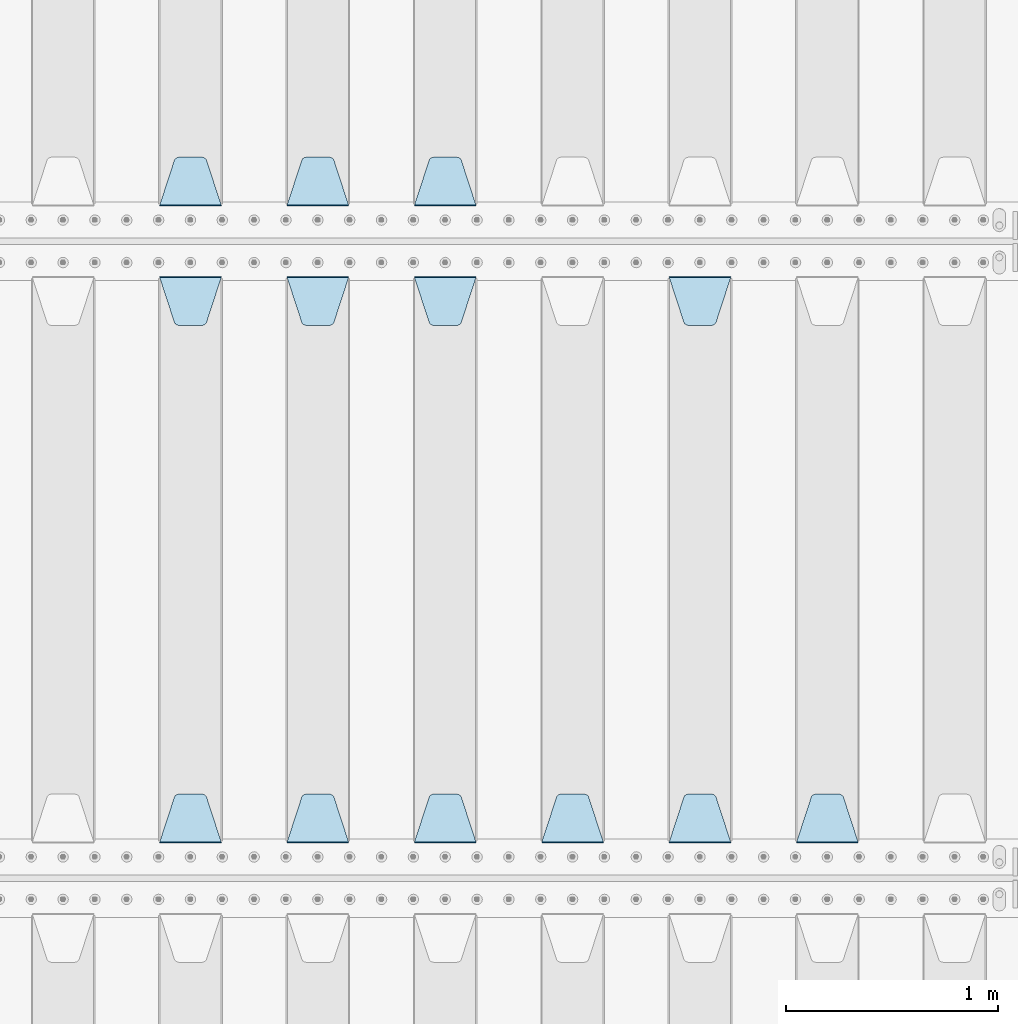
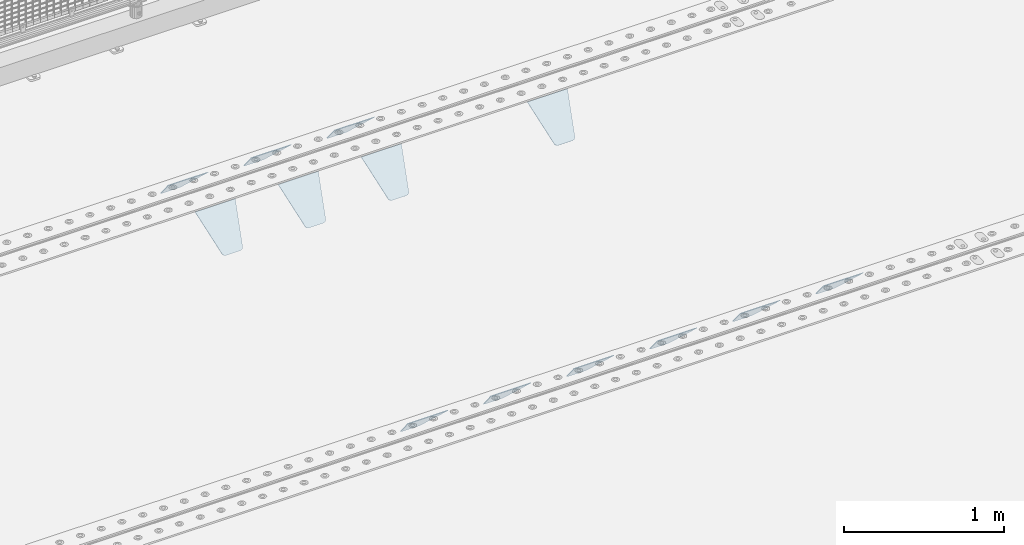
# One storey, part 219 of 270: 13 plates.
"""IFC2X3 building model written with IfcOpenShell, lengths in millimetres."""

from ifc_helpers import new_model, si_unit, frame, origin_with_axes, place, context, subcontext, project, spatial, faceted_brep, material, type_object, element, save


model = new_model("IFC2X3")

# Units and contexts
model_context = context("Model", 3, precision=1e-05, world=origin_with_axes())
body_context = subcontext(model_context, "Body", "Model", "MODEL_VIEW")
ifc_project = project(units=[si_unit("LENGTHUNIT", "METRE", prefix="MILLI"), si_unit("AREAUNIT", "SQUARE_METRE"), si_unit("VOLUMEUNIT", "CUBIC_METRE"), si_unit("MASSUNIT", "GRAM", prefix="KILO"), si_unit("TIMEUNIT", "SECOND"), si_unit("PLANEANGLEUNIT", "RADIAN"), si_unit("SOLIDANGLEUNIT", "STERADIAN"), si_unit("THERMODYNAMICTEMPERATUREUNIT", "DEGREE_CELSIUS"), si_unit("LUMINOUSINTENSITYUNIT", "LUMEN")], contexts=[model_context])

# Site, building, storey
site_placement = place(None, origin_with_axes())
site = spatial("IfcSite", under=ifc_project, at=site_placement, CompositionType="ELEMENT")
building_placement = place(site_placement, origin_with_axes())
building = spatial("IfcBuilding", under=site, at=building_placement, Name="Standard", CompositionType="ELEMENT")
storey_placement = place(building_placement, origin_with_axes())
storey = spatial("IfcBuildingStorey", under=building, at=storey_placement, Name="Undefined", CompositionType="ELEMENT", Elevation=0.0)

# Plates
ifc_material = material(Name="STEEL/S355N")
plate_type = type_object("IfcPlateType", PredefinedType="NOTDEFINED")
plate_1_placement = place(storey_placement, frame((4745.0, -17831.767766953, -1.76776695296758), z_axis=(0.0, 0.707106781186547, -0.707106781186548), x_axis=(-1.0, 0.0, 0.0)))
element("IfcPlate", 1, at=plate_1_placement, inside=storey, type_object=plate_type, material=ifc_material, context=body_context, shape_type="Brep", body=[
    faceted_brep([(0.0, -2.5, 0.0), (69.345504679477, -2.5, 300.171731424831), (69.345504679477, 2.5, 300.171731424831), (0.0, 2.5, 0.0), (70.9274061199576, -2.5, 304.8974424154), (70.9274061199576, 2.5, 304.8974424154), (73.3818627772307, -2.49999999999818, 309.234538108527), (73.3818627772307, 2.50000000000182, 309.234538108527), (76.6187032999551, -2.5, 313.023683126103), (76.6187032999551, 2.5, 313.023683126103), (80.5190132704993, -2.5, 316.125672595372), (80.5190132704993, 2.50000000000182, 316.125672595372), (84.9395038596849, -2.49999999999818, 318.426546230476), (84.9395038596849, 2.5, 318.426546230476), (89.7177759439219, -2.49999999999818, 319.841774983275), (89.7177759439219, 2.50000000000182, 319.841774983275), (94.678286292652, -2.5, 320.319366455078), (94.678286292652, 2.5, 320.319366455078), (195.321713707348, -2.5, 320.319366455078), (195.321713707348, 2.5, 320.319366455078), (200.282224056078, -2.49999999999818, 319.841774983275), (200.282224056078, 2.50000000000182, 319.841774983275), (205.060496140315, -2.5, 318.426546230476), (205.060496140315, 2.5, 318.426546230476), (209.480986729501, -2.5, 316.12567259537), (209.480986729501, 2.50000000000182, 316.12567259537), (213.381296700045, -2.5, 313.023683126103), (213.381296700045, 2.5, 313.023683126103), (216.618137222769, -2.49999999999818, 309.234538108525), (216.618137222769, 2.50000000000182, 309.234538108527), (219.072593880042, -2.49999999999818, 304.897442415398), (219.072593880042, 2.50000000000182, 304.897442415397), (220.654495320523, -2.5, 300.171731424831), (220.654495320523, 2.5, 300.171731424831), (290.0, -2.49999999999818, 0.0), (290.0, 2.5, 0.0)], [[[0, 1, 2, 3]], [[1, 4, 5, 2]], [[4, 6, 7, 5]], [[6, 8, 9, 7]], [[8, 10, 11, 9]], [[10, 12, 13, 11]], [[12, 14, 15, 13]], [[14, 16, 17, 15]], [[16, 18, 19, 17]], [[18, 20, 21, 19]], [[20, 22, 23, 21]], [[22, 24, 25, 23]], [[24, 26, 27, 25]], [[26, 28, 29, 27]], [[28, 30, 31, 29]], [[30, 32, 33, 31]], [[32, 34, 35, 33]], [[34, 0, 3, 35]], [[5, 7, 9, 11, 13, 15, 17, 19, 21, 23, 25, 27, 29, 31, 33, 35, 3, 2]], [[34, 32, 30, 28, 26, 24, 22, 20, 18, 16, 14, 12, 10, 8, 6, 4, 1, 0]]]),
])
plate_2_placement = place(storey_placement, frame((4145.0, -17831.767766953, -1.76776695296758), z_axis=(0.0, 0.707106781186547, -0.707106781186548), x_axis=(-1.0, 0.0, 0.0)))
element("IfcPlate", 2, at=plate_2_placement, inside=storey, type_object=plate_type, material=ifc_material, context=body_context, shape_type="Brep", body=[
    faceted_brep([(0.0, -2.5, 0.0), (69.345504679477, -2.5, 300.171731424831), (69.345504679477, 2.5, 300.171731424831), (0.0, 2.5, 0.0), (70.9274061199576, -2.5, 304.8974424154), (70.9274061199576, 2.5, 304.8974424154), (73.3818627772307, -2.49999999999818, 309.234538108527), (73.3818627772307, 2.50000000000182, 309.234538108527), (76.6187032999551, -2.5, 313.023683126103), (76.6187032999551, 2.5, 313.023683126103), (80.5190132704993, -2.5, 316.125672595372), (80.5190132704993, 2.50000000000182, 316.125672595372), (84.9395038596849, -2.49999999999818, 318.426546230476), (84.9395038596849, 2.5, 318.426546230476), (89.7177759439219, -2.49999999999818, 319.841774983275), (89.7177759439219, 2.50000000000182, 319.841774983275), (94.678286292652, -2.5, 320.319366455078), (94.678286292652, 2.5, 320.319366455078), (195.321713707348, -2.5, 320.319366455078), (195.321713707348, 2.5, 320.319366455078), (200.282224056078, -2.49999999999818, 319.841774983275), (200.282224056078, 2.50000000000182, 319.841774983275), (205.060496140315, -2.5, 318.426546230476), (205.060496140315, 2.5, 318.426546230476), (209.480986729501, -2.5, 316.12567259537), (209.480986729501, 2.50000000000182, 316.12567259537), (213.381296700045, -2.5, 313.023683126103), (213.381296700045, 2.5, 313.023683126103), (216.618137222769, -2.49999999999818, 309.234538108525), (216.618137222769, 2.50000000000182, 309.234538108527), (219.072593880042, -2.49999999999818, 304.897442415398), (219.072593880042, 2.50000000000182, 304.897442415397), (220.654495320523, -2.5, 300.171731424831), (220.654495320523, 2.5, 300.171731424831), (290.0, -2.49999999999818, 0.0), (290.0, 2.5, 0.0)], [[[0, 1, 2, 3]], [[1, 4, 5, 2]], [[4, 6, 7, 5]], [[6, 8, 9, 7]], [[8, 10, 11, 9]], [[10, 12, 13, 11]], [[12, 14, 15, 13]], [[14, 16, 17, 15]], [[16, 18, 19, 17]], [[18, 20, 21, 19]], [[20, 22, 23, 21]], [[22, 24, 25, 23]], [[24, 26, 27, 25]], [[26, 28, 29, 27]], [[28, 30, 31, 29]], [[30, 32, 33, 31]], [[32, 34, 35, 33]], [[34, 0, 3, 35]], [[5, 7, 9, 11, 13, 15, 17, 19, 21, 23, 25, 27, 29, 31, 33, 35, 3, 2]], [[34, 32, 30, 28, 26, 24, 22, 20, 18, 16, 14, 12, 10, 8, 6, 4, 1, 0]]]),
])
plate_3_placement = place(storey_placement, frame((3545.0, -17831.767766953, -1.76776695296758), z_axis=(0.0, 0.707106781186547, -0.707106781186548), x_axis=(-1.0, 0.0, 0.0)))
element("IfcPlate", 3, at=plate_3_placement, inside=storey, type_object=plate_type, material=ifc_material, context=body_context, shape_type="Brep", body=[
    faceted_brep([(0.0, -2.5, 0.0), (69.345504679477, -2.5, 300.171731424831), (69.345504679477, 2.5, 300.171731424831), (0.0, 2.5, 0.0), (70.9274061199576, -2.5, 304.8974424154), (70.9274061199576, 2.5, 304.8974424154), (73.3818627772307, -2.49999999999818, 309.234538108527), (73.3818627772307, 2.50000000000182, 309.234538108527), (76.6187032999551, -2.5, 313.023683126103), (76.6187032999551, 2.5, 313.023683126103), (80.5190132704993, -2.5, 316.125672595372), (80.5190132704993, 2.50000000000182, 316.125672595372), (84.9395038596849, -2.49999999999818, 318.426546230476), (84.9395038596849, 2.5, 318.426546230476), (89.7177759439219, -2.49999999999818, 319.841774983275), (89.7177759439219, 2.50000000000182, 319.841774983275), (94.678286292652, -2.5, 320.319366455078), (94.678286292652, 2.5, 320.319366455078), (195.321713707348, -2.5, 320.319366455078), (195.321713707348, 2.5, 320.319366455078), (200.282224056078, -2.49999999999818, 319.841774983275), (200.282224056078, 2.50000000000182, 319.841774983275), (205.060496140315, -2.5, 318.426546230476), (205.060496140315, 2.5, 318.426546230476), (209.480986729501, -2.5, 316.12567259537), (209.480986729501, 2.50000000000182, 316.12567259537), (213.381296700045, -2.5, 313.023683126103), (213.381296700045, 2.5, 313.023683126103), (216.618137222769, -2.49999999999818, 309.234538108525), (216.618137222769, 2.50000000000182, 309.234538108527), (219.072593880042, -2.49999999999818, 304.897442415398), (219.072593880042, 2.50000000000182, 304.897442415397), (220.654495320523, -2.5, 300.171731424831), (220.654495320523, 2.5, 300.171731424831), (290.0, -2.49999999999818, 0.0), (290.0, 2.5, 0.0)], [[[0, 1, 2, 3]], [[1, 4, 5, 2]], [[4, 6, 7, 5]], [[6, 8, 9, 7]], [[8, 10, 11, 9]], [[10, 12, 13, 11]], [[12, 14, 15, 13]], [[14, 16, 17, 15]], [[16, 18, 19, 17]], [[18, 20, 21, 19]], [[20, 22, 23, 21]], [[22, 24, 25, 23]], [[24, 26, 27, 25]], [[26, 28, 29, 27]], [[28, 30, 31, 29]], [[30, 32, 33, 31]], [[32, 34, 35, 33]], [[34, 0, 3, 35]], [[5, 7, 9, 11, 13, 15, 17, 19, 21, 23, 25, 27, 29, 31, 33, 35, 3, 2]], [[34, 32, 30, 28, 26, 24, 22, 20, 18, 16, 14, 12, 10, 8, 6, 4, 1, 0]]]),
])
plate_4_placement = place(storey_placement, frame((6545.0, -20831.767766953, -1.76776695296758), z_axis=(0.0, 0.707106781186547, -0.707106781186548), x_axis=(-1.0, 0.0, 0.0)))
element("IfcPlate", 4, at=plate_4_placement, inside=storey, type_object=plate_type, material=ifc_material, context=body_context, shape_type="Brep", body=[
    faceted_brep([(0.0, -2.5, 0.0), (69.345504679477, -2.5, 300.171731424831), (69.345504679477, 2.5, 300.171731424831), (0.0, 2.5, 0.0), (70.9274061199576, -2.5, 304.8974424154), (70.9274061199576, 2.5, 304.8974424154), (73.3818627772307, -2.49999999999818, 309.234538108527), (73.3818627772307, 2.50000000000182, 309.234538108527), (76.6187032999551, -2.5, 313.023683126103), (76.6187032999551, 2.5, 313.023683126103), (80.5190132704993, -2.5, 316.125672595372), (80.5190132704993, 2.50000000000182, 316.125672595372), (84.9395038596849, -2.49999999999818, 318.426546230476), (84.9395038596849, 2.5, 318.426546230476), (89.7177759439219, -2.49999999999818, 319.841774983275), (89.7177759439219, 2.50000000000182, 319.841774983275), (94.678286292652, -2.5, 320.319366455078), (94.678286292652, 2.5, 320.319366455078), (195.321713707348, -2.5, 320.319366455078), (195.321713707348, 2.5, 320.319366455078), (200.282224056078, -2.49999999999818, 319.841774983275), (200.282224056078, 2.50000000000182, 319.841774983275), (205.060496140315, -2.5, 318.426546230476), (205.060496140315, 2.5, 318.426546230476), (209.480986729501, -2.5, 316.12567259537), (209.480986729501, 2.50000000000182, 316.12567259537), (213.381296700045, -2.5, 313.023683126103), (213.381296700045, 2.5, 313.023683126103), (216.618137222769, -2.49999999999818, 309.234538108525), (216.618137222769, 2.50000000000182, 309.234538108527), (219.072593880042, -2.49999999999818, 304.897442415398), (219.072593880042, 2.50000000000182, 304.897442415397), (220.654495320523, -2.5, 300.171731424831), (220.654495320523, 2.5, 300.171731424831), (290.0, -2.49999999999818, 0.0), (290.0, 2.5, 0.0)], [[[0, 1, 2, 3]], [[1, 4, 5, 2]], [[4, 6, 7, 5]], [[6, 8, 9, 7]], [[8, 10, 11, 9]], [[10, 12, 13, 11]], [[12, 14, 15, 13]], [[14, 16, 17, 15]], [[16, 18, 19, 17]], [[18, 20, 21, 19]], [[20, 22, 23, 21]], [[22, 24, 25, 23]], [[24, 26, 27, 25]], [[26, 28, 29, 27]], [[28, 30, 31, 29]], [[30, 32, 33, 31]], [[32, 34, 35, 33]], [[34, 0, 3, 35]], [[5, 7, 9, 11, 13, 15, 17, 19, 21, 23, 25, 27, 29, 31, 33, 35, 3, 2]], [[34, 32, 30, 28, 26, 24, 22, 20, 18, 16, 14, 12, 10, 8, 6, 4, 1, 0]]]),
])
plate_5_placement = place(storey_placement, frame((5655.0, -18168.232233044, -1.76776695296576), z_axis=(0.0, -0.707106781186548, -0.707106781186547), x_axis=(1.0, 0.0, 0.0)))
element("IfcPlate", 5, at=plate_5_placement, inside=storey, type_object=plate_type, material=ifc_material, context=body_context, shape_type="Brep", body=[
    faceted_brep([(0.0, -2.5, 0.0), (69.345504679477, -2.5, 300.171731424831), (69.345504679477, 2.5, 300.171731424831), (0.0, 2.5, 0.0), (70.9274061199576, -2.5, 304.8974424154), (70.9274061199576, 2.5, 304.8974424154), (73.3818627772307, -2.49999999999818, 309.234538108527), (73.3818627772307, 2.50000000000182, 309.234538108527), (76.6187032999551, -2.5, 313.023683126103), (76.6187032999551, 2.5, 313.023683126103), (80.5190132704993, -2.5, 316.125672595372), (80.5190132704993, 2.50000000000182, 316.125672595372), (84.9395038596849, -2.49999999999818, 318.426546230476), (84.9395038596849, 2.5, 318.426546230476), (89.7177759439219, -2.49999999999818, 319.841774983275), (89.7177759439219, 2.50000000000182, 319.841774983275), (94.678286292652, -2.5, 320.319366455078), (94.678286292652, 2.5, 320.319366455078), (195.321713707348, -2.5, 320.319366455078), (195.321713707348, 2.5, 320.319366455078), (200.282224056078, -2.49999999999818, 319.841774983275), (200.282224056078, 2.50000000000182, 319.841774983275), (205.060496140315, -2.5, 318.426546230476), (205.060496140315, 2.5, 318.426546230476), (209.480986729501, -2.5, 316.12567259537), (209.480986729501, 2.50000000000182, 316.12567259537), (213.381296700045, -2.5, 313.023683126103), (213.381296700045, 2.5, 313.023683126103), (216.618137222769, -2.49999999999818, 309.234538108525), (216.618137222769, 2.50000000000182, 309.234538108527), (219.072593880042, -2.49999999999818, 304.897442415398), (219.072593880042, 2.50000000000182, 304.897442415397), (220.654495320523, -2.5, 300.171731424831), (220.654495320523, 2.5, 300.171731424831), (290.0, -2.49999999999818, 0.0), (290.0, 2.5, 0.0)], [[[0, 1, 2, 3]], [[1, 4, 5, 2]], [[4, 6, 7, 5]], [[6, 8, 9, 7]], [[8, 10, 11, 9]], [[10, 12, 13, 11]], [[12, 14, 15, 13]], [[14, 16, 17, 15]], [[16, 18, 19, 17]], [[18, 20, 21, 19]], [[20, 22, 23, 21]], [[22, 24, 25, 23]], [[24, 26, 27, 25]], [[26, 28, 29, 27]], [[28, 30, 31, 29]], [[30, 32, 33, 31]], [[32, 34, 35, 33]], [[34, 0, 3, 35]], [[5, 7, 9, 11, 13, 15, 17, 19, 21, 23, 25, 27, 29, 31, 33, 35, 3, 2]], [[34, 32, 30, 28, 26, 24, 22, 20, 18, 16, 14, 12, 10, 8, 6, 4, 1, 0]]]),
])
plate_6_placement = place(storey_placement, frame((5945.0, -20831.767766953, -1.76776695296758), z_axis=(0.0, 0.707106781186547, -0.707106781186548), x_axis=(-1.0, 0.0, 0.0)))
element("IfcPlate", 6, at=plate_6_placement, inside=storey, type_object=plate_type, material=ifc_material, context=body_context, shape_type="Brep", body=[
    faceted_brep([(0.0, -2.5, 0.0), (69.345504679477, -2.5, 300.171731424831), (69.345504679477, 2.5, 300.171731424831), (0.0, 2.5, 0.0), (70.9274061199576, -2.5, 304.8974424154), (70.9274061199576, 2.5, 304.8974424154), (73.3818627772307, -2.49999999999818, 309.234538108527), (73.3818627772307, 2.50000000000182, 309.234538108527), (76.6187032999551, -2.5, 313.023683126103), (76.6187032999551, 2.5, 313.023683126103), (80.5190132704993, -2.5, 316.125672595372), (80.5190132704993, 2.50000000000182, 316.125672595372), (84.9395038596849, -2.49999999999818, 318.426546230476), (84.9395038596849, 2.5, 318.426546230476), (89.7177759439219, -2.49999999999818, 319.841774983275), (89.7177759439219, 2.50000000000182, 319.841774983275), (94.678286292652, -2.5, 320.319366455078), (94.678286292652, 2.5, 320.319366455078), (195.321713707348, -2.5, 320.319366455078), (195.321713707348, 2.5, 320.319366455078), (200.282224056078, -2.49999999999818, 319.841774983275), (200.282224056078, 2.50000000000182, 319.841774983275), (205.060496140315, -2.5, 318.426546230476), (205.060496140315, 2.5, 318.426546230476), (209.480986729501, -2.5, 316.12567259537), (209.480986729501, 2.50000000000182, 316.12567259537), (213.381296700045, -2.5, 313.023683126103), (213.381296700045, 2.5, 313.023683126103), (216.618137222769, -2.49999999999818, 309.234538108525), (216.618137222769, 2.50000000000182, 309.234538108527), (219.072593880042, -2.49999999999818, 304.897442415398), (219.072593880042, 2.50000000000182, 304.897442415397), (220.654495320523, -2.5, 300.171731424831), (220.654495320523, 2.5, 300.171731424831), (290.0, -2.49999999999818, 0.0), (290.0, 2.5, 0.0)], [[[0, 1, 2, 3]], [[1, 4, 5, 2]], [[4, 6, 7, 5]], [[6, 8, 9, 7]], [[8, 10, 11, 9]], [[10, 12, 13, 11]], [[12, 14, 15, 13]], [[14, 16, 17, 15]], [[16, 18, 19, 17]], [[18, 20, 21, 19]], [[20, 22, 23, 21]], [[22, 24, 25, 23]], [[24, 26, 27, 25]], [[26, 28, 29, 27]], [[28, 30, 31, 29]], [[30, 32, 33, 31]], [[32, 34, 35, 33]], [[34, 0, 3, 35]], [[5, 7, 9, 11, 13, 15, 17, 19, 21, 23, 25, 27, 29, 31, 33, 35, 3, 2]], [[34, 32, 30, 28, 26, 24, 22, 20, 18, 16, 14, 12, 10, 8, 6, 4, 1, 0]]]),
])
plate_7_placement = place(storey_placement, frame((5345.0, -20831.767766953, -1.76776695296758), z_axis=(0.0, 0.707106781186547, -0.707106781186548), x_axis=(-1.0, 0.0, 0.0)))
element("IfcPlate", 7, at=plate_7_placement, inside=storey, type_object=plate_type, material=ifc_material, context=body_context, shape_type="Brep", body=[
    faceted_brep([(0.0, -2.5, 0.0), (69.345504679477, -2.5, 300.171731424831), (69.345504679477, 2.5, 300.171731424831), (0.0, 2.5, 0.0), (70.9274061199576, -2.5, 304.8974424154), (70.9274061199576, 2.5, 304.8974424154), (73.3818627772307, -2.49999999999818, 309.234538108527), (73.3818627772307, 2.50000000000182, 309.234538108527), (76.6187032999551, -2.5, 313.023683126103), (76.6187032999551, 2.5, 313.023683126103), (80.5190132704993, -2.5, 316.125672595372), (80.5190132704993, 2.50000000000182, 316.125672595372), (84.9395038596849, -2.49999999999818, 318.426546230476), (84.9395038596849, 2.5, 318.426546230476), (89.7177759439219, -2.49999999999818, 319.841774983275), (89.7177759439219, 2.50000000000182, 319.841774983275), (94.678286292652, -2.5, 320.319366455078), (94.678286292652, 2.5, 320.319366455078), (195.321713707348, -2.5, 320.319366455078), (195.321713707348, 2.5, 320.319366455078), (200.282224056078, -2.49999999999818, 319.841774983275), (200.282224056078, 2.50000000000182, 319.841774983275), (205.060496140315, -2.5, 318.426546230476), (205.060496140315, 2.5, 318.426546230476), (209.480986729501, -2.5, 316.12567259537), (209.480986729501, 2.50000000000182, 316.12567259537), (213.381296700045, -2.5, 313.023683126103), (213.381296700045, 2.5, 313.023683126103), (216.618137222769, -2.49999999999818, 309.234538108525), (216.618137222769, 2.50000000000182, 309.234538108527), (219.072593880042, -2.49999999999818, 304.897442415398), (219.072593880042, 2.50000000000182, 304.897442415397), (220.654495320523, -2.5, 300.171731424831), (220.654495320523, 2.5, 300.171731424831), (290.0, -2.49999999999818, 0.0), (290.0, 2.5, 0.0)], [[[0, 1, 2, 3]], [[1, 4, 5, 2]], [[4, 6, 7, 5]], [[6, 8, 9, 7]], [[8, 10, 11, 9]], [[10, 12, 13, 11]], [[12, 14, 15, 13]], [[14, 16, 17, 15]], [[16, 18, 19, 17]], [[18, 20, 21, 19]], [[20, 22, 23, 21]], [[22, 24, 25, 23]], [[24, 26, 27, 25]], [[26, 28, 29, 27]], [[28, 30, 31, 29]], [[30, 32, 33, 31]], [[32, 34, 35, 33]], [[34, 0, 3, 35]], [[5, 7, 9, 11, 13, 15, 17, 19, 21, 23, 25, 27, 29, 31, 33, 35, 3, 2]], [[34, 32, 30, 28, 26, 24, 22, 20, 18, 16, 14, 12, 10, 8, 6, 4, 1, 0]]]),
])
plate_8_placement = place(storey_placement, frame((4455.0, -18168.232233044, -1.76776695296576), z_axis=(0.0, -0.707106781186548, -0.707106781186547), x_axis=(1.0, 0.0, 0.0)))
element("IfcPlate", 8, at=plate_8_placement, inside=storey, type_object=plate_type, material=ifc_material, context=body_context, shape_type="Brep", body=[
    faceted_brep([(0.0, -2.5, 0.0), (69.345504679477, -2.5, 300.171731424831), (69.345504679477, 2.5, 300.171731424831), (0.0, 2.5, 0.0), (70.9274061199576, -2.5, 304.8974424154), (70.9274061199576, 2.5, 304.8974424154), (73.3818627772307, -2.49999999999818, 309.234538108527), (73.3818627772307, 2.50000000000182, 309.234538108527), (76.6187032999551, -2.5, 313.023683126103), (76.6187032999551, 2.5, 313.023683126103), (80.5190132704993, -2.5, 316.125672595372), (80.5190132704993, 2.50000000000182, 316.125672595372), (84.9395038596849, -2.49999999999818, 318.426546230476), (84.9395038596849, 2.5, 318.426546230476), (89.7177759439219, -2.49999999999818, 319.841774983275), (89.7177759439219, 2.50000000000182, 319.841774983275), (94.678286292652, -2.5, 320.319366455078), (94.678286292652, 2.5, 320.319366455078), (195.321713707348, -2.5, 320.319366455078), (195.321713707348, 2.5, 320.319366455078), (200.282224056078, -2.49999999999818, 319.841774983275), (200.282224056078, 2.50000000000182, 319.841774983275), (205.060496140315, -2.5, 318.426546230476), (205.060496140315, 2.5, 318.426546230476), (209.480986729501, -2.5, 316.12567259537), (209.480986729501, 2.50000000000182, 316.12567259537), (213.381296700045, -2.5, 313.023683126103), (213.381296700045, 2.5, 313.023683126103), (216.618137222769, -2.49999999999818, 309.234538108525), (216.618137222769, 2.50000000000182, 309.234538108527), (219.072593880042, -2.49999999999818, 304.897442415398), (219.072593880042, 2.50000000000182, 304.897442415397), (220.654495320523, -2.5, 300.171731424831), (220.654495320523, 2.5, 300.171731424831), (290.0, -2.49999999999818, 0.0), (290.0, 2.5, 0.0)], [[[0, 1, 2, 3]], [[1, 4, 5, 2]], [[4, 6, 7, 5]], [[6, 8, 9, 7]], [[8, 10, 11, 9]], [[10, 12, 13, 11]], [[12, 14, 15, 13]], [[14, 16, 17, 15]], [[16, 18, 19, 17]], [[18, 20, 21, 19]], [[20, 22, 23, 21]], [[22, 24, 25, 23]], [[24, 26, 27, 25]], [[26, 28, 29, 27]], [[28, 30, 31, 29]], [[30, 32, 33, 31]], [[32, 34, 35, 33]], [[34, 0, 3, 35]], [[5, 7, 9, 11, 13, 15, 17, 19, 21, 23, 25, 27, 29, 31, 33, 35, 3, 2]], [[34, 32, 30, 28, 26, 24, 22, 20, 18, 16, 14, 12, 10, 8, 6, 4, 1, 0]]]),
])
plate_9_placement = place(storey_placement, frame((4745.0, -20831.767766953, -1.76776695296758), z_axis=(0.0, 0.707106781186547, -0.707106781186548), x_axis=(-1.0, 0.0, 0.0)))
element("IfcPlate", 9, at=plate_9_placement, inside=storey, type_object=plate_type, material=ifc_material, context=body_context, shape_type="Brep", body=[
    faceted_brep([(0.0, -2.5, 0.0), (69.345504679477, -2.5, 300.171731424831), (69.345504679477, 2.5, 300.171731424831), (0.0, 2.5, 0.0), (70.9274061199576, -2.5, 304.8974424154), (70.9274061199576, 2.5, 304.8974424154), (73.3818627772307, -2.49999999999818, 309.234538108527), (73.3818627772307, 2.50000000000182, 309.234538108527), (76.6187032999551, -2.5, 313.023683126103), (76.6187032999551, 2.5, 313.023683126103), (80.5190132704993, -2.5, 316.125672595372), (80.5190132704993, 2.50000000000182, 316.125672595372), (84.9395038596849, -2.49999999999818, 318.426546230476), (84.9395038596849, 2.5, 318.426546230476), (89.7177759439219, -2.49999999999818, 319.841774983275), (89.7177759439219, 2.50000000000182, 319.841774983275), (94.678286292652, -2.5, 320.319366455078), (94.678286292652, 2.5, 320.319366455078), (195.321713707348, -2.5, 320.319366455078), (195.321713707348, 2.5, 320.319366455078), (200.282224056078, -2.49999999999818, 319.841774983275), (200.282224056078, 2.50000000000182, 319.841774983275), (205.060496140315, -2.5, 318.426546230476), (205.060496140315, 2.5, 318.426546230476), (209.480986729501, -2.5, 316.12567259537), (209.480986729501, 2.50000000000182, 316.12567259537), (213.381296700045, -2.5, 313.023683126103), (213.381296700045, 2.5, 313.023683126103), (216.618137222769, -2.49999999999818, 309.234538108525), (216.618137222769, 2.50000000000182, 309.234538108527), (219.072593880042, -2.49999999999818, 304.897442415398), (219.072593880042, 2.50000000000182, 304.897442415397), (220.654495320523, -2.5, 300.171731424831), (220.654495320523, 2.5, 300.171731424831), (290.0, -2.49999999999818, 0.0), (290.0, 2.5, 0.0)], [[[0, 1, 2, 3]], [[1, 4, 5, 2]], [[4, 6, 7, 5]], [[6, 8, 9, 7]], [[8, 10, 11, 9]], [[10, 12, 13, 11]], [[12, 14, 15, 13]], [[14, 16, 17, 15]], [[16, 18, 19, 17]], [[18, 20, 21, 19]], [[20, 22, 23, 21]], [[22, 24, 25, 23]], [[24, 26, 27, 25]], [[26, 28, 29, 27]], [[28, 30, 31, 29]], [[30, 32, 33, 31]], [[32, 34, 35, 33]], [[34, 0, 3, 35]], [[5, 7, 9, 11, 13, 15, 17, 19, 21, 23, 25, 27, 29, 31, 33, 35, 3, 2]], [[34, 32, 30, 28, 26, 24, 22, 20, 18, 16, 14, 12, 10, 8, 6, 4, 1, 0]]]),
])
plate_10_placement = place(storey_placement, frame((3855.0, -18168.232233044, -1.76776695296576), z_axis=(0.0, -0.707106781186548, -0.707106781186547), x_axis=(1.0, 0.0, 0.0)))
element("IfcPlate", 10, at=plate_10_placement, inside=storey, type_object=plate_type, material=ifc_material, context=body_context, shape_type="Brep", body=[
    faceted_brep([(0.0, -2.5, 0.0), (69.345504679477, -2.5, 300.171731424831), (69.345504679477, 2.5, 300.171731424831), (0.0, 2.5, 0.0), (70.9274061199576, -2.5, 304.8974424154), (70.9274061199576, 2.5, 304.8974424154), (73.3818627772307, -2.49999999999818, 309.234538108527), (73.3818627772307, 2.50000000000182, 309.234538108527), (76.6187032999551, -2.5, 313.023683126103), (76.6187032999551, 2.5, 313.023683126103), (80.5190132704993, -2.5, 316.125672595372), (80.5190132704993, 2.50000000000182, 316.125672595372), (84.9395038596849, -2.49999999999818, 318.426546230476), (84.9395038596849, 2.5, 318.426546230476), (89.7177759439219, -2.49999999999818, 319.841774983275), (89.7177759439219, 2.50000000000182, 319.841774983275), (94.678286292652, -2.5, 320.319366455078), (94.678286292652, 2.5, 320.319366455078), (195.321713707348, -2.5, 320.319366455078), (195.321713707348, 2.5, 320.319366455078), (200.282224056078, -2.49999999999818, 319.841774983275), (200.282224056078, 2.50000000000182, 319.841774983275), (205.060496140315, -2.5, 318.426546230476), (205.060496140315, 2.5, 318.426546230476), (209.480986729501, -2.5, 316.12567259537), (209.480986729501, 2.50000000000182, 316.12567259537), (213.381296700045, -2.5, 313.023683126103), (213.381296700045, 2.5, 313.023683126103), (216.618137222769, -2.49999999999818, 309.234538108525), (216.618137222769, 2.50000000000182, 309.234538108527), (219.072593880042, -2.49999999999818, 304.897442415398), (219.072593880042, 2.50000000000182, 304.897442415397), (220.654495320523, -2.5, 300.171731424831), (220.654495320523, 2.5, 300.171731424831), (290.0, -2.49999999999818, 0.0), (290.0, 2.5, 0.0)], [[[0, 1, 2, 3]], [[1, 4, 5, 2]], [[4, 6, 7, 5]], [[6, 8, 9, 7]], [[8, 10, 11, 9]], [[10, 12, 13, 11]], [[12, 14, 15, 13]], [[14, 16, 17, 15]], [[16, 18, 19, 17]], [[18, 20, 21, 19]], [[20, 22, 23, 21]], [[22, 24, 25, 23]], [[24, 26, 27, 25]], [[26, 28, 29, 27]], [[28, 30, 31, 29]], [[30, 32, 33, 31]], [[32, 34, 35, 33]], [[34, 0, 3, 35]], [[5, 7, 9, 11, 13, 15, 17, 19, 21, 23, 25, 27, 29, 31, 33, 35, 3, 2]], [[34, 32, 30, 28, 26, 24, 22, 20, 18, 16, 14, 12, 10, 8, 6, 4, 1, 0]]]),
])
plate_11_placement = place(storey_placement, frame((4145.0, -20831.767766953, -1.76776695296758), z_axis=(0.0, 0.707106781186547, -0.707106781186548), x_axis=(-1.0, 0.0, 0.0)))
element("IfcPlate", 11, at=plate_11_placement, inside=storey, type_object=plate_type, material=ifc_material, context=body_context, shape_type="Brep", body=[
    faceted_brep([(0.0, -2.5, 0.0), (69.345504679477, -2.5, 300.171731424831), (69.345504679477, 2.5, 300.171731424831), (0.0, 2.5, 0.0), (70.9274061199576, -2.5, 304.8974424154), (70.9274061199576, 2.5, 304.8974424154), (73.3818627772307, -2.49999999999818, 309.234538108527), (73.3818627772307, 2.50000000000182, 309.234538108527), (76.6187032999551, -2.5, 313.023683126103), (76.6187032999551, 2.5, 313.023683126103), (80.5190132704993, -2.5, 316.125672595372), (80.5190132704993, 2.50000000000182, 316.125672595372), (84.9395038596849, -2.49999999999818, 318.426546230476), (84.9395038596849, 2.5, 318.426546230476), (89.7177759439219, -2.49999999999818, 319.841774983275), (89.7177759439219, 2.50000000000182, 319.841774983275), (94.678286292652, -2.5, 320.319366455078), (94.678286292652, 2.5, 320.319366455078), (195.321713707348, -2.5, 320.319366455078), (195.321713707348, 2.5, 320.319366455078), (200.282224056078, -2.49999999999818, 319.841774983275), (200.282224056078, 2.50000000000182, 319.841774983275), (205.060496140315, -2.5, 318.426546230476), (205.060496140315, 2.5, 318.426546230476), (209.480986729501, -2.5, 316.12567259537), (209.480986729501, 2.50000000000182, 316.12567259537), (213.381296700045, -2.5, 313.023683126103), (213.381296700045, 2.5, 313.023683126103), (216.618137222769, -2.49999999999818, 309.234538108525), (216.618137222769, 2.50000000000182, 309.234538108527), (219.072593880042, -2.49999999999818, 304.897442415398), (219.072593880042, 2.50000000000182, 304.897442415397), (220.654495320523, -2.5, 300.171731424831), (220.654495320523, 2.5, 300.171731424831), (290.0, -2.49999999999818, 0.0), (290.0, 2.5, 0.0)], [[[0, 1, 2, 3]], [[1, 4, 5, 2]], [[4, 6, 7, 5]], [[6, 8, 9, 7]], [[8, 10, 11, 9]], [[10, 12, 13, 11]], [[12, 14, 15, 13]], [[14, 16, 17, 15]], [[16, 18, 19, 17]], [[18, 20, 21, 19]], [[20, 22, 23, 21]], [[22, 24, 25, 23]], [[24, 26, 27, 25]], [[26, 28, 29, 27]], [[28, 30, 31, 29]], [[30, 32, 33, 31]], [[32, 34, 35, 33]], [[34, 0, 3, 35]], [[5, 7, 9, 11, 13, 15, 17, 19, 21, 23, 25, 27, 29, 31, 33, 35, 3, 2]], [[34, 32, 30, 28, 26, 24, 22, 20, 18, 16, 14, 12, 10, 8, 6, 4, 1, 0]]]),
])
plate_12_placement = place(storey_placement, frame((3255.0, -18168.232233044, -1.76776695296576), z_axis=(0.0, -0.707106781186548, -0.707106781186547), x_axis=(1.0, 0.0, 0.0)))
element("IfcPlate", 12, at=plate_12_placement, inside=storey, type_object=plate_type, material=ifc_material, context=body_context, shape_type="Brep", body=[
    faceted_brep([(0.0, -2.5, 0.0), (69.345504679477, -2.5, 300.171731424831), (69.345504679477, 2.5, 300.171731424831), (0.0, 2.5, 0.0), (70.9274061199576, -2.5, 304.8974424154), (70.9274061199576, 2.5, 304.8974424154), (73.3818627772307, -2.49999999999818, 309.234538108527), (73.3818627772307, 2.50000000000182, 309.234538108527), (76.6187032999551, -2.5, 313.023683126103), (76.6187032999551, 2.5, 313.023683126103), (80.5190132704993, -2.5, 316.125672595372), (80.5190132704993, 2.50000000000182, 316.125672595372), (84.9395038596849, -2.49999999999818, 318.426546230476), (84.9395038596849, 2.5, 318.426546230476), (89.7177759439219, -2.49999999999818, 319.841774983275), (89.7177759439219, 2.50000000000182, 319.841774983275), (94.678286292652, -2.5, 320.319366455078), (94.678286292652, 2.5, 320.319366455078), (195.321713707348, -2.5, 320.319366455078), (195.321713707348, 2.5, 320.319366455078), (200.282224056078, -2.49999999999818, 319.841774983275), (200.282224056078, 2.50000000000182, 319.841774983275), (205.060496140315, -2.5, 318.426546230476), (205.060496140315, 2.5, 318.426546230476), (209.480986729501, -2.5, 316.12567259537), (209.480986729501, 2.50000000000182, 316.12567259537), (213.381296700045, -2.5, 313.023683126103), (213.381296700045, 2.5, 313.023683126103), (216.618137222769, -2.49999999999818, 309.234538108525), (216.618137222769, 2.50000000000182, 309.234538108527), (219.072593880042, -2.49999999999818, 304.897442415398), (219.072593880042, 2.50000000000182, 304.897442415397), (220.654495320523, -2.5, 300.171731424831), (220.654495320523, 2.5, 300.171731424831), (290.0, -2.49999999999818, 0.0), (290.0, 2.5, 0.0)], [[[0, 1, 2, 3]], [[1, 4, 5, 2]], [[4, 6, 7, 5]], [[6, 8, 9, 7]], [[8, 10, 11, 9]], [[10, 12, 13, 11]], [[12, 14, 15, 13]], [[14, 16, 17, 15]], [[16, 18, 19, 17]], [[18, 20, 21, 19]], [[20, 22, 23, 21]], [[22, 24, 25, 23]], [[24, 26, 27, 25]], [[26, 28, 29, 27]], [[28, 30, 31, 29]], [[30, 32, 33, 31]], [[32, 34, 35, 33]], [[34, 0, 3, 35]], [[5, 7, 9, 11, 13, 15, 17, 19, 21, 23, 25, 27, 29, 31, 33, 35, 3, 2]], [[34, 32, 30, 28, 26, 24, 22, 20, 18, 16, 14, 12, 10, 8, 6, 4, 1, 0]]]),
])
plate_13_placement = place(storey_placement, frame((3545.0, -20831.767766953, -1.76776695296758), z_axis=(0.0, 0.707106781186547, -0.707106781186548), x_axis=(-1.0, 0.0, 0.0)))
element("IfcPlate", 13, at=plate_13_placement, inside=storey, type_object=plate_type, material=ifc_material, context=body_context, shape_type="Brep", body=[
    faceted_brep([(0.0, -2.5, 0.0), (69.345504679477, -2.5, 300.171731424831), (69.345504679477, 2.5, 300.171731424831), (0.0, 2.5, 0.0), (70.9274061199576, -2.5, 304.8974424154), (70.9274061199576, 2.5, 304.8974424154), (73.3818627772307, -2.49999999999818, 309.234538108527), (73.3818627772307, 2.50000000000182, 309.234538108527), (76.6187032999551, -2.5, 313.023683126103), (76.6187032999551, 2.5, 313.023683126103), (80.5190132704993, -2.5, 316.125672595372), (80.5190132704993, 2.50000000000182, 316.125672595372), (84.9395038596849, -2.49999999999818, 318.426546230476), (84.9395038596849, 2.5, 318.426546230476), (89.7177759439219, -2.49999999999818, 319.841774983275), (89.7177759439219, 2.50000000000182, 319.841774983275), (94.678286292652, -2.5, 320.319366455078), (94.678286292652, 2.5, 320.319366455078), (195.321713707348, -2.5, 320.319366455078), (195.321713707348, 2.5, 320.319366455078), (200.282224056078, -2.49999999999818, 319.841774983275), (200.282224056078, 2.50000000000182, 319.841774983275), (205.060496140315, -2.5, 318.426546230476), (205.060496140315, 2.5, 318.426546230476), (209.480986729501, -2.5, 316.12567259537), (209.480986729501, 2.50000000000182, 316.12567259537), (213.381296700045, -2.5, 313.023683126103), (213.381296700045, 2.5, 313.023683126103), (216.618137222769, -2.49999999999818, 309.234538108525), (216.618137222769, 2.50000000000182, 309.234538108527), (219.072593880042, -2.49999999999818, 304.897442415398), (219.072593880042, 2.50000000000182, 304.897442415397), (220.654495320523, -2.5, 300.171731424831), (220.654495320523, 2.5, 300.171731424831), (290.0, -2.49999999999818, 0.0), (290.0, 2.5, 0.0)], [[[0, 1, 2, 3]], [[1, 4, 5, 2]], [[4, 6, 7, 5]], [[6, 8, 9, 7]], [[8, 10, 11, 9]], [[10, 12, 13, 11]], [[12, 14, 15, 13]], [[14, 16, 17, 15]], [[16, 18, 19, 17]], [[18, 20, 21, 19]], [[20, 22, 23, 21]], [[22, 24, 25, 23]], [[24, 26, 27, 25]], [[26, 28, 29, 27]], [[28, 30, 31, 29]], [[30, 32, 33, 31]], [[32, 34, 35, 33]], [[34, 0, 3, 35]], [[5, 7, 9, 11, 13, 15, 17, 19, 21, 23, 25, 27, 29, 31, 33, 35, 3, 2]], [[34, 32, 30, 28, 26, 24, 22, 20, 18, 16, 14, 12, 10, 8, 6, 4, 1, 0]]]),
])

save(model, "model.ifc")
